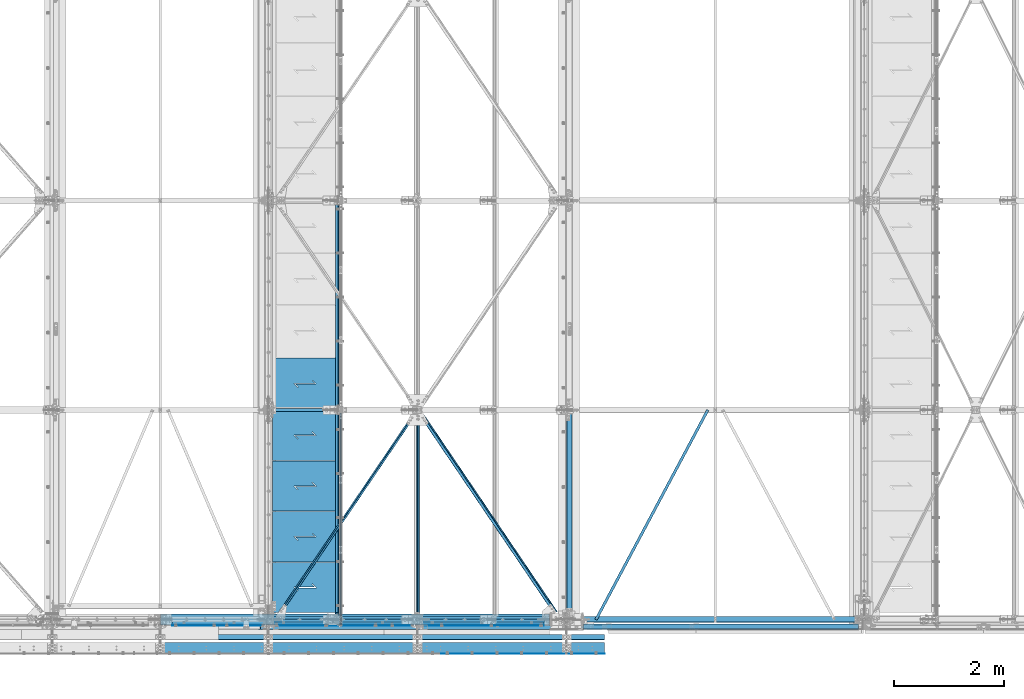
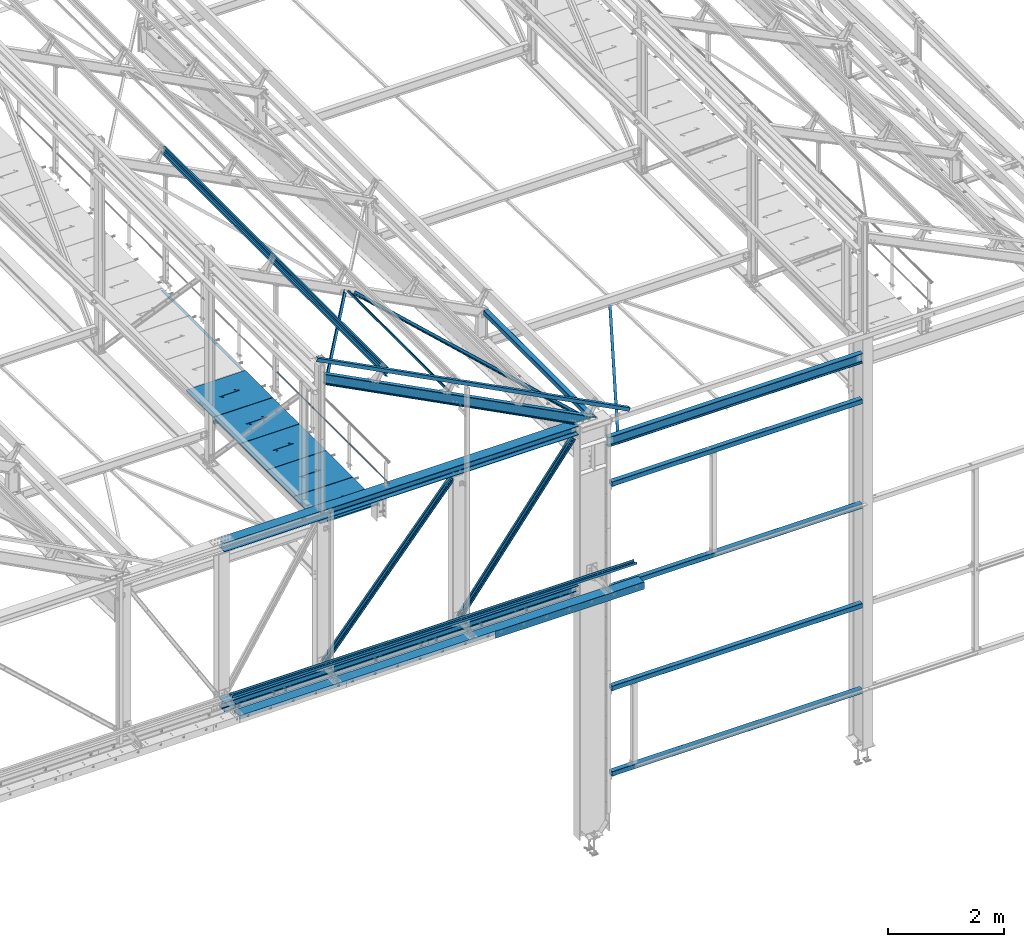
# One storey, part 48 of 496: 26 beams, 6 members, 32 elements without a shape of their own.
"""IFC2X3 building model written with IfcOpenShell, lengths in millimetres."""

from ifc_helpers import new_model, si_unit, frame, origin_with_axes, origin_2d_with_axis, place, context, subcontext, project, spatial, polyline, rectangle, hollow_rectangle, hollow_circle, i_section, l_section, u_section, outline, extrude, boolean, clip, halfspace, material, type_object, element, aggregate, save


model = new_model("IFC2X3")

# Units and contexts
model_context = context("Model", 3, precision=1e-05, world=origin_with_axes())
body_context = subcontext(model_context, "Body", "Model", "MODEL_VIEW")
ifc_project = project(units=[si_unit("LENGTHUNIT", "METRE", prefix="MILLI"), si_unit("AREAUNIT", "SQUARE_METRE"), si_unit("VOLUMEUNIT", "CUBIC_METRE"), si_unit("MASSUNIT", "GRAM", prefix="KILO"), si_unit("TIMEUNIT", "SECOND"), si_unit("PLANEANGLEUNIT", "RADIAN"), si_unit("SOLIDANGLEUNIT", "STERADIAN"), si_unit("THERMODYNAMICTEMPERATUREUNIT", "DEGREE_CELSIUS"), si_unit("LUMINOUSINTENSITYUNIT", "LUMEN")], contexts=[model_context])

# Site, building, storey
site_placement = place(None, origin_with_axes())
site = spatial("IfcSite", under=ifc_project, at=site_placement, CompositionType="ELEMENT")
building_placement = place(site_placement, origin_with_axes())
building = spatial("IfcBuilding", under=site, at=building_placement, Name="Undefined", CompositionType="ELEMENT")
storey_placement = place(building_placement, origin_with_axes())
storey = spatial("IfcBuildingStorey", under=building, at=storey_placement, Name="Undefined", CompositionType="ELEMENT", Elevation=0.0)

# Assembly, beam
assembly_1_placement = place(storey_placement, origin_with_axes())
assembly_1 = element("IfcElementAssembly", 1, at=assembly_1_placement, inside=storey, AssemblyPlace="NOTDEFINED", PredefinedType="NOTDEFINED")
ifc_material_1 = material(Name="Undefined/S235-E24")
beam_type_1 = type_object("IfcBeamType", PredefinedType="NOTDEFINED")
beam_1_placement = place(assembly_1_placement, frame((29413.2405270353, -3.98847032546837, 7825.02116772689), z_axis=(0.882450948164099, -0.47017230311602, 0.0147759760036461), x_axis=(0.470404426089172, 0.882015499167199, -0.0277188590052545)))
beam_1 = element("IfcBeam", 2, at=beam_1_placement, type_object=beam_type_1, material=ifc_material_1, context=body_context, shape_type="SweptSolid", body=[
    extrude(l_section(Depth=50.0, Width=50.0, Thickness=5.0, FilletRadius=7.0, EdgeRadius=3.5, at=origin_2d_with_axis()), frame((4311.66067509402, 8.94535623785865e-13, 6.6380908567593e-14), z_axis=(-1.0, 0.0, 0.0), x_axis=(0.0, -1.0, 0.0)), (0.0, 0.0, 1.0), 4311.66),
])
aggregate(assembly_1, [beam_1])

assembly_2_placement = place(storey_placement, origin_with_axes())
assembly_2 = element("IfcElementAssembly", 3, at=assembly_2_placement, inside=storey, Name="SUPPORT", AssemblyPlace="NOTDEFINED", PredefinedType="NOTDEFINED")
beam_2_placement = place(assembly_2_placement, frame((24711.491600332, 7595.00000000005, 8075.0), z_axis=(-1.0, 0.0, 0.0), x_axis=(0.0, -1.0, 0.0)))
beam_2 = element("IfcBeam", 4, at=beam_2_placement, type_object=beam_type_1, material=ifc_material_1, Name="SUPPORT", context=body_context, shape_type="SweptSolid", body=[
    extrude(l_section(Depth=50.0, Width=50.0, Thickness=5.0, FilletRadius=7.0, EdgeRadius=3.5, at=origin_2d_with_axis()), frame((7469.99982384897, 0.0, 0.0), z_axis=(-1.0, 0.0, 0.0), x_axis=(0.0, -1.0, 0.0)), (0.0, 0.0, 1.0), 7470.0),
])
aggregate(assembly_2, [beam_2])

assembly_3_placement = place(storey_placement, origin_with_axes())
assembly_3 = element("IfcElementAssembly", 5, at=assembly_3_placement, inside=storey, AssemblyPlace="NOTDEFINED", PredefinedType="NOTDEFINED")
beam_type_2 = type_object("IfcBeamType", PredefinedType="NOTDEFINED")
beam_3_placement = place(assembly_3_placement, frame((28762.7486131771, 1.81867566696019, 8583.73904157683), z_axis=(-0.70611707829274, -0.606225541427049, 0.365908820151697), x_axis=(-0.538249840883414, 0.79529277182776, 0.278920267939601)))
beam_3 = element("IfcBeam", 6, at=beam_3_placement, type_object=beam_type_2, material=ifc_material_1, context=body_context, shape_type="Clipping", body=[
    clip(clip(extrude(l_section(Depth=60.0, Width=60.0, Thickness=6.0, FilletRadius=8.0, EdgeRadius=4.0, at=origin_2d_with_axis()), frame((4708.91289425565, 0.0, -3.8340266889476e-12), z_axis=(-1.0, 0.0, 0.0), x_axis=(0.0, -1.0, 0.0)), (0.0, 0.0, 1.0), 4639.71), halfspace(frame((4626.03085826945, 29.999945784366, -30.0000015337173), z_axis=(-1.0, 0.0, 0.0), x_axis=(0.0, 0.0, 1.0)), True)), halfspace(frame((152.084204273029, 29.9999207803739, 29.9999999275933), z_axis=(1.0, 0.0, 0.0), x_axis=(0.0, 0.0, -1.0)), True)),
])
aggregate(assembly_3, [beam_3])

assembly_4_placement = place(storey_placement, origin_with_axes())
assembly_4 = element("IfcElementAssembly", 7, at=assembly_4_placement, inside=storey, AssemblyPlace="NOTDEFINED", PredefinedType="NOTDEFINED")
beam_4_placement = place(assembly_4_placement, frame((26186.6844465445, 3801.81867700377, 9918.65169572219), z_axis=(0.706117063313599, -0.606225551624848, -0.365908832162506), x_axis=(-0.538249844036752, -0.795292764054313, 0.27892028401904)))
beam_4 = element("IfcBeam", 8, at=beam_4_placement, type_object=beam_type_2, material=ifc_material_1, context=body_context, shape_type="Clipping", body=[
    clip(clip(extrude(l_section(Depth=60.0, Width=60.0, Thickness=6.0, FilletRadius=8.0, EdgeRadius=4.0, at=origin_2d_with_axis()), frame((4700.97218490528, -1.30478188945107e-13, 5.21912755780427e-13), z_axis=(-1.0, 0.0, 0.0), x_axis=(0.0, -1.0, 0.0)), (0.0, 0.0, 1.0), 4623.83), halfspace(frame((4626.03039444976, 29.9999208122827, 29.999999976033), z_axis=(-1.0, 0.0, 0.0), x_axis=(0.0, -1.0, 0.0)), True)), halfspace(frame((152.083740436687, 29.999946654003, -29.9999999681386), z_axis=(1.0, 0.0, 0.0), x_axis=(0.0, -1.0, 0.0)), True)),
])
aggregate(assembly_4, [beam_4])

assembly_5_placement = place(storey_placement, origin_with_axes())
assembly_5 = element("IfcElementAssembly", 9, at=assembly_5_placement, inside=storey, Name="SUPPORT", AssemblyPlace="NOTDEFINED", PredefinedType="NOTDEFINED")
beam_type_3 = type_object("IfcBeamType", PredefinedType="NOTDEFINED")
beam_5_placement = place(assembly_5_placement, frame((26605.0000059717, -622.0, 5154.99824538435), z_axis=(0.0, 0.0, 1.0), x_axis=(1.0, 0.0, 0.0)))
beam_5 = element("IfcBeam", 10, at=beam_5_placement, type_object=beam_type_3, material=ifc_material_1, Name="SUPPORT", context=body_context, shape_type="SweptSolid", body=[
    extrude(rectangle(XDim=4.0, YDim=150.0, at=origin_2d_with_axis()), frame((2964.99999402831, 0.0, 0.0), z_axis=(-1.0, 0.0, 0.0), x_axis=(0.0, -1.0, 0.0)), (0.0, 0.0, 1.0), 2965.0),
])
aggregate(assembly_5, [beam_5])

assembly_6_placement = place(storey_placement, origin_with_axes())
assembly_6 = element("IfcElementAssembly", 11, at=assembly_6_placement, inside=storey, Name="SUPPORT", AssemblyPlace="NOTDEFINED", PredefinedType="NOTDEFINED")
beam_type_4 = type_object("IfcBeamType", PredefinedType="NOTDEFINED")
beam_6_placement = place(assembly_6_placement, frame((29570.0, -320.0, 5474.99824538435), z_axis=(0.0, -1.0, 0.0), x_axis=(-1.0, 0.0, 0.0)))
beam_6 = element("IfcBeam", 12, at=beam_6_placement, type_object=beam_type_4, material=ifc_material_1, Name="SUPPORT", context=body_context, shape_type="SweptSolid", body=[
    extrude(u_section(Depth=100.0, FlangeWidth=50.0, WebThickness=4.0, FlangeThickness=4.0, at=origin_2d_with_axis()), frame((8055.00000597169, 0.0, 0.0), z_axis=(-1.0, 0.0, 0.0), x_axis=(0.0, -1.0, 0.0)), (0.0, 0.0, 1.0), 8055.0),
])
aggregate(assembly_6, [beam_6])

assembly_7_placement = place(storey_placement, origin_with_axes())
assembly_7 = element("IfcElementAssembly", 13, at=assembly_7_placement, inside=storey, Name="SUPPORT", AssemblyPlace="NOTDEFINED", PredefinedType="NOTDEFINED")
ifc_material_2 = material(Name="Undefined/S275-E28")
beam_type_5 = type_object("IfcBeamType", Name="UPN200", PredefinedType="NOTDEFINED")
beam_7_placement = place(assembly_7_placement, frame((21514.9999940283, -520.0, 5192.49824538435), z_axis=(0.0, -1.0, 0.0), x_axis=(1.0, 0.0, 0.0)))
beam_7 = element("IfcBeam", 14, at=beam_7_placement, type_object=beam_type_5, material=ifc_material_2, Name="SUPPORT", ObjectType="UPN200", context=body_context, shape_type="SweptSolid", body=[
    extrude(u_section(Depth=200.0, FlangeWidth=75.0, WebThickness=8.5, FlangeThickness=11.5, FilletRadius=11.5, EdgeRadius=6.0, FlangeSlope=0.0798299857122373, at=origin_2d_with_axis()), frame((8055.00000597169, 0.0, 0.0), z_axis=(-1.0, 0.0, 0.0), x_axis=(0.0, -1.0, 0.0)), (0.0, 0.0, 1.0), 8055.0),
])
aggregate(assembly_7, [beam_7])

assembly_8_placement = place(storey_placement, origin_with_axes())
assembly_8 = element("IfcElementAssembly", 15, at=assembly_8_placement, inside=storey, Name="SUPPORT", AssemblyPlace="NOTDEFINED", PredefinedType="NOTDEFINED")
beam_type_6 = type_object("IfcBeamType", PredefinedType="NOTDEFINED")
beam_8_placement = place(assembly_8_placement, frame((21730.0012583757, -105.0, 5040.00085614788), z_axis=(0.0, 0.0, 1.0), x_axis=(1.0, 0.0, 0.0)))
beam_8 = element("IfcBeam", 16, at=beam_8_placement, type_object=beam_type_6, material=ifc_material_1, Name="SUPPORT", context=body_context, shape_type="SweptSolid", body=[
    extrude(rectangle(XDim=10.0, YDim=80.0, at=origin_2d_with_axis()), frame((6734.99874155707, 2.78553019229252e-21, 0.0), z_axis=(-1.0, 0.0, 0.0), x_axis=(0.0, -1.0, 0.0)), (0.0, 0.0, 1.0), 6735.0),
])
aggregate(assembly_8, [beam_8])

assembly_9_placement = place(storey_placement, origin_with_axes())
assembly_9 = element("IfcElementAssembly", 17, at=assembly_9_placement, inside=storey, Name="LISSE", AssemblyPlace="NOTDEFINED", PredefinedType="NOTDEFINED")
beam_type_7 = type_object("IfcBeamType", PredefinedType="NOTDEFINED")
beam_9_placement = place(assembly_9_placement, frame((29185.0000015707, -129.999823796242, 7150.00000003501), z_axis=(0.0, 0.0, -1.0), x_axis=(1.0, 0.0, 0.0)))
beam_9 = element("IfcBeam", 18, at=beam_9_placement, type_object=beam_type_7, material=ifc_material_1, Name="LISSE", context=body_context, shape_type="SweptSolid", body=[
    extrude(hollow_rectangle(XDim=100.0, YDim=100.0, WallThickness=4.0, InnerFilletRadius=4.0, OuterFilletRadius=8.0, at=origin_2d_with_axis()), frame((4989.99999787802, 9.78039819338819e-22, 0.0), z_axis=(-1.0, 0.0, 0.0), x_axis=(0.0, -1.0, 0.0)), (0.0, 0.0, 1.0), 4990.0),
])
aggregate(assembly_9, [beam_9])

assembly_10_placement = place(storey_placement, origin_with_axes())
assembly_10 = element("IfcElementAssembly", 19, at=assembly_10_placement, inside=storey, Name="LISSE", AssemblyPlace="NOTDEFINED", PredefinedType="NOTDEFINED")
beam_10_placement = place(assembly_10_placement, frame((29185.0000022644, -129.999823796467, 4950.00000003405), z_axis=(0.0, 0.0, 1.0), x_axis=(1.0, 0.0, 0.0)))
beam_10 = element("IfcBeam", 20, at=beam_10_placement, type_object=beam_type_7, material=ifc_material_1, Name="LISSE", context=body_context, shape_type="SweptSolid", body=[
    extrude(hollow_rectangle(XDim=100.0, YDim=100.0, WallThickness=4.0, InnerFilletRadius=4.0, OuterFilletRadius=8.0, at=origin_2d_with_axis()), frame((4989.99999787802, 9.78039819338819e-22, 0.0), z_axis=(-1.0, 0.0, 0.0), x_axis=(0.0, -1.0, 0.0)), (0.0, 0.0, 1.0), 4990.0),
])
aggregate(assembly_10, [beam_10])

assembly_11_placement = place(storey_placement, origin_with_axes())
assembly_11 = element("IfcElementAssembly", 21, at=assembly_11_placement, inside=storey, Name="LISSE", AssemblyPlace="NOTDEFINED", PredefinedType="NOTDEFINED")
beam_11_placement = place(assembly_11_placement, frame((29185.0000015707, -129.999823796034, 2850.00000003501), z_axis=(0.0, 0.0, -1.0), x_axis=(1.0, 0.0, 0.0)))
beam_11 = element("IfcBeam", 22, at=beam_11_placement, type_object=beam_type_7, material=ifc_material_1, Name="LISSE", context=body_context, shape_type="SweptSolid", body=[
    extrude(hollow_rectangle(XDim=100.0, YDim=100.0, WallThickness=4.0, InnerFilletRadius=4.0, OuterFilletRadius=8.0, at=origin_2d_with_axis()), frame((4989.99999787802, 9.78039819338819e-22, 0.0), z_axis=(-1.0, 0.0, 0.0), x_axis=(0.0, -1.0, 0.0)), (0.0, 0.0, 1.0), 4990.0),
])
aggregate(assembly_11, [beam_11])

assembly_12_placement = place(storey_placement, origin_with_axes())
assembly_12 = element("IfcElementAssembly", 23, at=assembly_12_placement, inside=storey, Name="LISSE", AssemblyPlace="NOTDEFINED", PredefinedType="NOTDEFINED")
beam_12_placement = place(assembly_12_placement, frame((29185.0000022644, -129.999823796391, 1050.00000003405), z_axis=(0.0, 0.0, 1.0), x_axis=(1.0, 0.0, 0.0)))
beam_12 = element("IfcBeam", 24, at=beam_12_placement, type_object=beam_type_7, material=ifc_material_1, Name="LISSE", context=body_context, shape_type="SweptSolid", body=[
    extrude(hollow_rectangle(XDim=100.0, YDim=100.0, WallThickness=4.0, InnerFilletRadius=4.0, OuterFilletRadius=8.0, at=origin_2d_with_axis()), frame((4989.99999787802, 9.78039819338819e-22, 0.0), z_axis=(-1.0, 0.0, 0.0), x_axis=(0.0, -1.0, 0.0)), (0.0, 0.0, 1.0), 4990.0),
])
aggregate(assembly_12, [beam_12])

assembly_13_placement = place(storey_placement, origin_with_axes())
assembly_13 = element("IfcElementAssembly", 25, at=assembly_13_placement, inside=storey, Name="LISSE", AssemblyPlace="NOTDEFINED", PredefinedType="NOTDEFINED")
beam_13_placement = place(assembly_13_placement, frame((28929.9999999877, 120.0, 8500.0), z_axis=(0.0, 0.0, 1.0), x_axis=(0.0, 1.0, 0.0)))
beam_13 = element("IfcBeam", 26, at=beam_13_placement, type_object=beam_type_7, material=ifc_material_1, Name="LISSE", context=body_context, shape_type="SweptSolid", body=[
    extrude(hollow_rectangle(XDim=100.0, YDim=100.0, WallThickness=4.0, InnerFilletRadius=4.0, OuterFilletRadius=8.0, at=origin_2d_with_axis()), frame((3610.0, 0.0, 0.0), z_axis=(-1.0, 0.0, 0.0), x_axis=(0.0, -1.0, 0.0)), (0.0, 0.0, 1.0), 3610.0),
])
aggregate(assembly_13, [beam_13])

assembly_14_placement = place(storey_placement, origin_with_axes())
assembly_14 = element("IfcElementAssembly", 27, at=assembly_14_placement, inside=storey, AssemblyPlace="NOTDEFINED", PredefinedType="NOTDEFINED")
beam_type_8 = type_object("IfcBeamType", PredefinedType="NOTDEFINED")
beam_14_placement = place(assembly_14_placement, frame((24726.4916105611, 1035.00017615107, 8115.0), z_axis=(0.0, 0.0, 1.0), x_axis=(-1.0, 0.0, 0.0)))
beam_14 = element("IfcBeam", 28, at=beam_14_placement, type_object=beam_type_8, material=ifc_material_1, context=body_context, shape_type="CSG", body=[
    boolean("DIFFERENCE", extrude(outline(polyline([(0.0, 0.0), (1179.99169921875, 0.0), (1179.99169921875, 910.0), (-9.39995516091585e-07, 910.0), (0.0, 0.0)])), frame((0.0, 0.0, -15.0), z_axis=(0.0, 0.0, 1.0), x_axis=(1.0, 0.0, 0.0)), (0.0, 0.0, 1.0), 30.0), extrude(outline(polyline([(0.0, 0.0), (9.99999999997453, 6.91215973347425e-11), (10.0000000004329, 75.8578643791443), (282.842712400121, -196.984848017997), (282.842712400743, -96.9848480190813), (272.842712400776, -96.9848480191613), (272.842712400299, -172.842712398218), (0.0, 100.0), (0.0, 0.0)])), frame((724.285170968404, 520.710678119967, -17.5), z_axis=(0.0, 0.0, 1.0), x_axis=(-0.707106781186457, -0.707106781186639, 0.0)), (0.0, 0.0, 1.0), 35.0)),
])
aggregate(assembly_14, [beam_14])

assembly_15_placement = place(storey_placement, origin_with_axes())
assembly_15 = element("IfcElementAssembly", 29, at=assembly_15_placement, inside=storey, AssemblyPlace="NOTDEFINED", PredefinedType="NOTDEFINED")
beam_15_placement = place(assembly_15_placement, frame((24726.4916105611, 1955.00017138181, 8115.0), z_axis=(0.0, 0.0, 1.0), x_axis=(-1.0, 0.0, 0.0)))
beam_15 = element("IfcBeam", 30, at=beam_15_placement, type_object=beam_type_8, material=ifc_material_1, context=body_context, shape_type="CSG", body=[
    boolean("DIFFERENCE", extrude(outline(polyline([(0.0, 0.0), (1179.99169921875, 0.0), (1179.99169921875, 910.0), (-9.39995516091585e-07, 910.0), (0.0, 0.0)])), frame((0.0, 0.0, -15.0), z_axis=(0.0, 0.0, 1.0), x_axis=(1.0, 0.0, 0.0)), (0.0, 0.0, 1.0), 30.0), extrude(outline(polyline([(0.0, 0.0), (9.99999999997453, 6.91215973347425e-11), (10.0000000004329, 75.8578643791443), (282.842712400121, -196.984848017997), (282.842712400743, -96.9848480190813), (272.842712400776, -96.9848480191613), (272.842712400299, -172.842712398218), (0.0, 100.0), (0.0, 0.0)])), frame((724.285170968404, 520.710678119967, -17.5), z_axis=(0.0, 0.0, 1.0), x_axis=(-0.707106781186457, -0.707106781186639, 0.0)), (0.0, 0.0, 1.0), 35.0)),
])
aggregate(assembly_15, [beam_15])

assembly_16_placement = place(storey_placement, origin_with_axes())
assembly_16 = element("IfcElementAssembly", 31, at=assembly_16_placement, inside=storey, AssemblyPlace="NOTDEFINED", PredefinedType="NOTDEFINED")
beam_16_placement = place(assembly_16_placement, frame((24726.4916105611, 2875.00016661255, 8115.0), z_axis=(0.0, 0.0, 1.0), x_axis=(-1.0, 0.0, 0.0)))
beam_16 = element("IfcBeam", 32, at=beam_16_placement, type_object=beam_type_8, material=ifc_material_1, context=body_context, shape_type="CSG", body=[
    boolean("DIFFERENCE", extrude(outline(polyline([(0.0, 0.0), (1179.99169921875, 0.0), (1179.99169921875, 910.0), (-9.39995516091585e-07, 910.0), (0.0, 0.0)])), frame((0.0, 0.0, -15.0), z_axis=(0.0, 0.0, 1.0), x_axis=(1.0, 0.0, 0.0)), (0.0, 0.0, 1.0), 30.0), extrude(outline(polyline([(0.0, 0.0), (9.99999999997453, 6.91215973347425e-11), (10.0000000004329, 75.8578643791443), (282.842712400121, -196.984848017997), (282.842712400743, -96.9848480190813), (272.842712400776, -96.9848480191613), (272.842712400299, -172.842712398218), (0.0, 100.0), (0.0, 0.0)])), frame((724.285170968404, 520.710678119967, -17.5), z_axis=(0.0, 0.0, 1.0), x_axis=(-0.707106781186457, -0.707106781186639, 0.0)), (0.0, 0.0, 1.0), 35.0)),
])
aggregate(assembly_16, [beam_16])

assembly_17_placement = place(storey_placement, origin_with_axes())
assembly_17 = element("IfcElementAssembly", 33, at=assembly_17_placement, inside=storey, AssemblyPlace="NOTDEFINED", PredefinedType="NOTDEFINED")
beam_17_placement = place(assembly_17_placement, frame((24726.4916105611, 3795.00016184328, 8115.0), z_axis=(0.0, 0.0, 1.0), x_axis=(-1.0, 0.0, 0.0)))
beam_17 = element("IfcBeam", 34, at=beam_17_placement, type_object=beam_type_8, material=ifc_material_1, context=body_context, shape_type="CSG", body=[
    boolean("DIFFERENCE", extrude(outline(polyline([(0.0, 0.0), (1179.99169921875, 0.0), (1179.99169921875, 910.0), (-9.39995516091585e-07, 910.0), (0.0, 0.0)])), frame((0.0, 0.0, -15.0), z_axis=(0.0, 0.0, 1.0), x_axis=(1.0, 0.0, 0.0)), (0.0, 0.0, 1.0), 30.0), extrude(outline(polyline([(0.0, 0.0), (9.99999999997453, 6.91215973347425e-11), (10.0000000004329, 75.8578643791443), (282.842712400121, -196.984848017997), (282.842712400743, -96.9848480190813), (272.842712400776, -96.9848480191613), (272.842712400299, -172.842712398218), (0.0, 100.0), (0.0, 0.0)])), frame((724.285170968404, 520.710678119967, -17.5), z_axis=(0.0, 0.0, 1.0), x_axis=(-0.707106781186457, -0.707106781186639, 0.0)), (0.0, 0.0, 1.0), 35.0)),
])
aggregate(assembly_17, [beam_17])

assembly_18_placement = place(storey_placement, origin_with_axes())
assembly_18 = element("IfcElementAssembly", 35, at=assembly_18_placement, inside=storey, AssemblyPlace="NOTDEFINED", PredefinedType="NOTDEFINED")
beam_type_9 = type_object("IfcBeamType", PredefinedType="NOTDEFINED")
beam_18_placement = place(assembly_18_placement, frame((24726.4915934611, 4745.00015707402, 8115.0), z_axis=(0.0, 0.0, 1.0), x_axis=(-1.0, 0.0, 0.0)))
beam_18 = element("IfcBeam", 36, at=beam_18_placement, type_object=beam_type_9, material=ifc_material_1, context=body_context, shape_type="CSG", body=[
    boolean("DIFFERENCE", extrude(outline(polyline([(0.0, 0.0), (1179.99169921875, 0.0), (1179.99169921875, 940.0), (-9.39995516091585e-07, 940.0), (0.0, 0.0)])), frame((0.0, 0.0, -15.0), z_axis=(0.0, 0.0, 1.0), x_axis=(1.0, 0.0, 0.0)), (0.0, 0.0, 1.0), 30.0), extrude(outline(polyline([(0.0, 0.0), (9.99999999997453, 6.91215973347425e-11), (10.0000000004329, 75.8578643791443), (282.842712400121, -196.984848017997), (282.842712400743, -96.9848480190813), (272.842712400776, -96.9848480191613), (272.842712400299, -172.842712398218), (0.0, 100.0), (0.0, 0.0)])), frame((724.286946489367, 535.710676888644, -17.5), z_axis=(0.0, 0.0, 1.0), x_axis=(-0.707106781186457, -0.707106781186639, 0.0)), (0.0, 0.0, 1.0), 35.0)),
])
aggregate(assembly_18, [beam_18])

assembly_19_placement = place(storey_placement, origin_with_axes())
assembly_19 = element("IfcElementAssembly", 37, at=assembly_19_placement, inside=storey, Name="SUPPORT", AssemblyPlace="NOTDEFINED", PredefinedType="NOTDEFINED")
beam_type_10 = type_object("IfcBeamType", PredefinedType="NOTDEFINED")
beam_19_placement = place(assembly_19_placement, frame((21730.0012582974, -64.998477916576, 5045.00085614788), z_axis=(0.0, 1.0, 0.0), x_axis=(1.0, 0.0, 0.0)))
beam_19 = element("IfcBeam", 38, at=beam_19_placement, type_object=beam_type_10, material=ifc_material_1, Name="SUPPORT", context=body_context, shape_type="SweptSolid", body=[
    extrude(l_section(Depth=70.0, Width=70.0, Thickness=7.0, FilletRadius=9.0, EdgeRadius=4.5, at=origin_2d_with_axis()), frame((6734.99874155707, 2.78553019229252e-21, 0.0), z_axis=(-1.0, 0.0, 0.0), x_axis=(0.0, -1.0, 0.0)), (0.0, 0.0, 1.0), 6735.0),
])
aggregate(assembly_19, [beam_19])

assembly_20_placement = place(storey_placement, origin_with_axes())
assembly_20 = element("IfcElementAssembly", 39, at=assembly_20_placement, inside=storey, Name="MAIN COURANTE", AssemblyPlace="NOTDEFINED", PredefinedType="NOTDEFINED")
beam_type_11 = type_object("IfcBeamType", PredefinedType="NOTDEFINED")
beam_20_placement = place(assembly_20_placement, frame((24783.9916006735, 3745.00000183788, 8673.80000478164), z_axis=(0.0, 0.0, 1.0), x_axis=(0.0, -1.0, 0.0)))
beam_20 = element("IfcBeam", 40, at=beam_20_placement, type_object=beam_type_11, material=ifc_material_1, Name="LISSE", context=body_context, shape_type="SweptSolid", body=[
    extrude(hollow_circle(Radius=13.44999981, WallThickness=2.0, at=origin_2d_with_axis()), frame((3844.99656169932, 3.84499533570735e-24, 0.0), z_axis=(-1.0, 0.0, 0.0), x_axis=(0.0, -1.0, 0.0)), (0.0, 0.0, 1.0), 3845.0),
])
aggregate(assembly_20, [beam_20])

assembly_21_placement = place(storey_placement, origin_with_axes())
assembly_21 = element("IfcElementAssembly", 41, at=assembly_21_placement, inside=storey, AssemblyPlace="NOTDEFINED", PredefinedType="NOTDEFINED")
beam_type_12 = type_object("IfcBeamType", PredefinedType="NOTDEFINED")
beam_21_placement = place(assembly_21_placement, frame((26184.2061440776, 3720.00174668243, 9908.67304621165), z_axis=(-0.887870604061621, -1.29999898490562e-08, 0.460093241031915), x_axis=(0.0, -1.0, 0.0)))
beam_21 = element("IfcBeam", 42, at=beam_21_placement, type_object=beam_type_12, material=ifc_material_1, context=body_context, shape_type="SweptSolid", body=[
    extrude(hollow_rectangle(XDim=40.0, YDim=40.0, WallThickness=4.0, InnerFilletRadius=4.0, OuterFilletRadius=8.0, at=origin_2d_with_axis()), frame((3700.00159576542, -3.63797880709171e-12, -3.63797880709171e-12), z_axis=(-1.0, 0.0, 0.0), x_axis=(0.0, -1.0, 0.0)), (0.0, 0.0, 1.0), 3700.0),
])
aggregate(assembly_21, [beam_21])

assembly_22_placement = place(storey_placement, origin_with_axes())
assembly_22 = element("IfcElementAssembly", 43, at=assembly_22_placement, inside=storey, Name="TRAVERSE BASSE", AssemblyPlace="NOTDEFINED", PredefinedType="NOTDEFINED")
beam_type_13 = type_object("IfcBeamType", Name="HEA200", PredefinedType="NOTDEFINED")
beam_22_placement = place(assembly_22_placement, frame((21514.9998483183, 0.0, 5095.00174292274), z_axis=(0.0, 0.0, 1.0), x_axis=(1.0, 0.0, 0.0)))
beam_22 = element("IfcBeam", 44, at=beam_22_placement, type_object=beam_type_13, material=ifc_material_2, Name="TRAVERSE BASSE", ObjectType="HEA200", context=body_context, shape_type="SweptSolid", body=[
    extrude(i_section(OverallWidth=200.0, OverallDepth=190.0, WebThickness=6.5, FlangeThickness=10.0, FilletRadius=18.0, at=origin_2d_with_axis()), frame((7055.00017515165, 0.0, 0.0), z_axis=(-1.0, 0.0, 0.0), x_axis=(0.0, -1.0, 0.0)), (0.0, 0.0, 1.0), 7055.0),
])
aggregate(assembly_22, [beam_22])

assembly_23_placement = place(storey_placement, origin_with_axes())
assembly_23 = element("IfcElementAssembly", 45, at=assembly_23_placement, inside=storey, Name="TRAVERSE HAUTE", AssemblyPlace="NOTDEFINED", PredefinedType="NOTDEFINED")
beam_23_placement = place(assembly_23_placement, frame((28569.99997653, 0.0, 8454.99444626714), z_axis=(0.0, 0.0, -1.0), x_axis=(-1.0, 0.0, 0.0)))
beam_23 = element("IfcBeam", 46, at=beam_23_placement, type_object=beam_type_13, material=ifc_material_2, Name="TRAVERSE HAUTE", ObjectType="HEA200", context=body_context, shape_type="SweptSolid", body=[
    extrude(i_section(OverallWidth=200.0, OverallDepth=190.0, WebThickness=6.5, FlangeThickness=10.0, FilletRadius=18.0, at=origin_2d_with_axis()), frame((7055.00017515165, 0.0, 0.0), z_axis=(-1.0, 0.0, 0.0), x_axis=(0.0, -1.0, 0.0)), (0.0, 0.0, 1.0), 7055.0),
])
aggregate(assembly_23, [beam_23])

assembly_24_placement = place(storey_placement, origin_with_axes())
assembly_24 = element("IfcElementAssembly", 47, at=assembly_24_placement, inside=storey, Name="SHED", AssemblyPlace="NOTDEFINED", PredefinedType="NOTDEFINED")
beam_type_14 = type_object("IfcBeamType", PredefinedType="NOTDEFINED")
beam_24_placement = place(assembly_24_placement, frame((24738.4311443321, -154.999920381521, 11040.8102083729), z_axis=(0.460093364927087, 0.0, 0.887870539859315), x_axis=(0.0, 1.0, 0.0)))
beam_24 = element("IfcBeam", 48, at=beam_24_placement, type_object=beam_type_14, material=ifc_material_1, Name="SHED", context=body_context, shape_type="SweptSolid", body=[
    extrude(outline(polyline([(-27.9999999860338, 36.0000000101354), (-27.999999986052, 70.0000000101354), (28.0000000138389, 70.0000000101209), (28.0000000138425, 58.0000000101209), (26.5000000138534, 58.0000000101209), (26.5000000138352, 68.5000000101172), (-26.4999999860593, 68.5000000101354), (-26.4999999860338, 36.7000007730749), (-1.49999998607018, 15.6999998194005), (-1.49999998605563, -15.6999997991297), (-26.4999999859974, -36.7000007527895), (-26.4999999859829, -68.49999998985), (26.5000000139153, -68.4999999898646), (26.500000013908, -57.9999999898646), (28.0000000139116, -57.9999999898646), (28.0000000139153, -69.9999999898646), (-27.9999999859756, -69.99999998985), (-27.9999999859901, -35.99999998985), (-2.99999998605927, -14.9999999898646), (-2.9999999860629, 15.0000000101354), (-27.9999999860338, 36.0000000101354)])), frame((7750.00000000006, -3.63797880548905e-12, 0.0), z_axis=(-1.0, 0.0, 0.0), x_axis=(0.0, -1.0, 0.0)), (0.0, 0.0, 1.0), 7750.0),
])
aggregate(assembly_24, [beam_24])

# Assembly, member
assembly_25_placement = place(storey_placement, origin_with_axes())
assembly_25 = element("IfcElementAssembly", 49, at=assembly_25_placement, inside=storey, AssemblyPlace="NOTDEFINED", PredefinedType="NOTDEFINED")
member_type_1 = type_object("IfcMemberType", PredefinedType="NOTDEFINED")
member_1_placement = place(assembly_25_placement, frame((23309.4127399744, -145.0, 11828.6296316058), z_axis=(-0.460093241820242, 0.0, -0.887870603653112), x_axis=(0.887870604061616, 0.0, -0.460093241031926)))
member_1 = element("IfcMember", 50, at=member_1_placement, type_object=member_type_1, material=ifc_material_1, context=body_context, shape_type="SweptSolid", body=[
    extrude(l_section(Depth=70.0, Width=70.0, Thickness=7.0, FilletRadius=9.0, EdgeRadius=4.5, at=origin_2d_with_axis()), frame((7015.00016857142, 0.0, -3.89410735244867e-13), z_axis=(-1.0, 0.0, 0.0), x_axis=(0.0, -1.0, 0.0)), (0.0, 0.0, 1.0), 7015.0),
])
aggregate(assembly_25, [member_1])

assembly_26_placement = place(storey_placement, origin_with_axes())
assembly_26 = element("IfcElementAssembly", 51, at=assembly_26_placement, inside=storey, AssemblyPlace="NOTDEFINED", PredefinedType="NOTDEFINED")
member_type_2 = type_object("IfcMemberType", Name="UPN80", PredefinedType="NOTDEFINED")
member_2_placement = place(assembly_26_placement, frame((23470.0000048533, 27.500000001548, 5190.00068964305), z_axis=(0.760694427649506, 0.0, -0.649110150700935), x_axis=(0.649110147977419, 0.0, 0.760694429973516)))
member_2 = element("IfcMember", 52, at=member_2_placement, type_object=member_type_2, material=ifc_material_2, ObjectType="UPN80", context=body_context, shape_type="Clipping", body=[
    clip(clip(extrude(u_section(Depth=80.0, FlangeWidth=45.0, WebThickness=6.0, FlangeThickness=8.0, FilletRadius=8.0, EdgeRadius=4.0, FlangeSlope=0.0798299857122373, at=origin_2d_with_axis()), frame((4127.0370906706, 3.5527136788005e-15, 4.58193160154452e-13), z_axis=(-1.0, 0.0, 0.0), x_axis=(0.0, -1.0, 0.0)), (0.0, 0.0, 1.0), 4086.83), halfspace(frame((4047.24313549228, 27.500000001548, -39.999999399286), z_axis=(-1.0, 0.0, 0.0), x_axis=(0.0, 1.0, 0.0)), True)), halfspace(frame((119.999999997919, 27.49999999375, -39.9999989691296), z_axis=(-1.0, 0.0, 0.0), x_axis=(0.0, 1.0, 0.0)), False)),
])
aggregate(assembly_26, [member_2])

assembly_27_placement = place(storey_placement, origin_with_axes())
assembly_27 = element("IfcElementAssembly", 53, at=assembly_27_placement, inside=storey, AssemblyPlace="NOTDEFINED", PredefinedType="NOTDEFINED")
member_3_placement = place(assembly_27_placement, frame((26174.9998359929, -27.5000000008872, 8359.9993116999), z_axis=(0.760694427649506, 0.0, -0.649110150700935), x_axis=(-0.649110150700935, 0.0, -0.760694427649506)))
member_3 = element("IfcMember", 54, at=member_3_placement, type_object=member_type_2, material=ifc_material_2, ObjectType="UPN80", context=body_context, shape_type="Clipping", body=[
    clip(clip(extrude(u_section(Depth=80.0, FlangeWidth=45.0, WebThickness=6.0, FlangeThickness=8.0, FilletRadius=8.0, EdgeRadius=4.0, FlangeSlope=0.0798299857122373, at=origin_2d_with_axis()), frame((4127.0370906706, 3.5527136788005e-15, 4.58193160154452e-13), z_axis=(-1.0, 0.0, 0.0), x_axis=(0.0, -1.0, 0.0)), (0.0, 0.0, 1.0), 4086.83), halfspace(frame((4047.24313549228, 27.500000001548, -39.999999399286), z_axis=(1.0, 0.0, 0.0), x_axis=(0.0, -1.0, 0.0)), False)), halfspace(frame((119.999999997919, 27.49999999375, -39.9999989691296), z_axis=(1.0, 0.0, 0.0), x_axis=(0.0, -1.0, 0.0)), True)),
])
aggregate(assembly_27, [member_3])

assembly_28_placement = place(storey_placement, origin_with_axes())
assembly_28 = element("IfcElementAssembly", 55, at=assembly_28_placement, inside=storey, AssemblyPlace="NOTDEFINED", PredefinedType="NOTDEFINED")
member_4_placement = place(assembly_28_placement, frame((26175.0000048474, 27.5000000069931, 5190.00624337595), z_axis=(0.79667022183209, 0.0, -0.604414226872604), x_axis=(0.604414210939447, 0.0, 0.796670233920187)))
member_4 = element("IfcMember", 56, at=member_4_placement, type_object=member_type_2, material=ifc_material_2, ObjectType="UPN80", context=body_context, shape_type="Clipping", body=[
    clip(clip(extrude(u_section(Depth=80.0, FlangeWidth=45.0, WebThickness=6.0, FlangeThickness=8.0, FilletRadius=8.0, EdgeRadius=4.0, FlangeSlope=0.0798299857122373, at=origin_2d_with_axis()), frame((3936.86625748963, 0.0, 0.0), z_axis=(-1.0, 0.0, 0.0), x_axis=(0.0, -1.0, 0.0)), (0.0, 0.0, 1.0), 3894.68), halfspace(frame((3859.05281738359, 27.5000000069931, -40.0000022367931), z_axis=(-1.0, 0.0, 0.0), x_axis=(0.0, 1.0, 0.0)), True)), halfspace(frame((119.999999997919, 27.49999999375, -39.9999989691296), z_axis=(-1.0, 0.0, 0.0), x_axis=(0.0, 1.0, 0.0)), False)),
])
aggregate(assembly_28, [member_4])

assembly_29_placement = place(storey_placement, origin_with_axes())
assembly_29 = element("IfcElementAssembly", 57, at=assembly_29_placement, inside=storey, AssemblyPlace="NOTDEFINED", PredefinedType="NOTDEFINED")
member_5_placement = place(assembly_29_placement, frame((28579.9960922618, -27.5000000018274, 8359.99916813926), z_axis=(0.79667022183209, 0.0, -0.604414226872604), x_axis=(-0.604414226872603, 0.0, -0.796670221832091)))
member_5 = element("IfcMember", 58, at=member_5_placement, type_object=member_type_2, material=ifc_material_2, ObjectType="UPN80", context=body_context, shape_type="Clipping", body=[
    clip(clip(extrude(u_section(Depth=80.0, FlangeWidth=45.0, WebThickness=6.0, FlangeThickness=8.0, FilletRadius=8.0, EdgeRadius=4.0, FlangeSlope=0.0798299857122373, at=origin_2d_with_axis()), frame((3936.86625748963, 0.0, 0.0), z_axis=(-1.0, 0.0, 0.0), x_axis=(0.0, -1.0, 0.0)), (0.0, 0.0, 1.0), 3894.68), halfspace(frame((3859.05281738359, 27.5000000069931, -40.0000022367931), z_axis=(1.0, 0.0, 0.0), x_axis=(0.0, -1.0, 0.0)), False)), halfspace(frame((119.999999997919, 27.49999999375, -39.9999989691296), z_axis=(1.0, 0.0, 0.0), x_axis=(0.0, -1.0, 0.0)), True)),
])
aggregate(assembly_29, [member_5])

# Assembly, beam
assembly_30_placement = place(storey_placement, origin_with_axes())
assembly_30 = element("IfcElementAssembly", 59, at=assembly_30_placement, inside=storey, AssemblyPlace="NOTDEFINED", PredefinedType="NOTDEFINED")
beam_type_15 = type_object("IfcBeamType", PredefinedType="NOTDEFINED")
beam_25_placement = place(assembly_30_placement, frame((23547.9918295866, 3800.0, 8015.0), z_axis=(0.0, -1.0, 0.0), x_axis=(1.0, 0.0, 0.0)))
beam_25 = element("IfcBeam", 60, at=beam_25_placement, type_object=beam_type_15, material=ifc_material_1, context=body_context, shape_type="SweptSolid", body=[
    extrude(hollow_rectangle(XDim=60.0, YDim=60.0, WallThickness=3.0, InnerFilletRadius=3.0, OuterFilletRadius=6.0, at=origin_2d_with_axis()), frame((1181.99977105896, 0.0, 0.0), z_axis=(-1.0, 0.0, 0.0), x_axis=(0.0, -1.0, 0.0)), (0.0, 0.0, 1.0), 1182.0),
])
aggregate(assembly_30, [beam_25])

# Assembly, member
assembly_31_placement = place(storey_placement, origin_with_axes())
assembly_31 = element("IfcElementAssembly", 61, at=assembly_31_placement, inside=storey, Name="TRAVERSE SHED", AssemblyPlace="NOTDEFINED", PredefinedType="NOTDEFINED")
member_type_3 = type_object("IfcMemberType", Name="IPE200", PredefinedType="NOTDEFINED")
member_6_placement = place(assembly_31_placement, frame((23493.9906758887, -3.18409305520222e-09, 11280.2129395988), z_axis=(0.460093364927087, 0.0, 0.887870539859315), x_axis=(0.887870604061616, 0.0, -0.460093241031926)))
member_6 = element("IfcMember", 62, at=member_6_placement, type_object=member_type_3, material=ifc_material_2, Name="TRAVERSE SHED", ObjectType="IPE200", context=body_context, shape_type="Clipping", body=[
    clip(clip(extrude(i_section(OverallWidth=100.0, OverallDepth=200.0, WebThickness=5.599999905, FlangeThickness=8.5, FilletRadius=12.0, at=origin_2d_with_axis()), frame((6159.55202464549, 4.13590306276514e-25, 0.0), z_axis=(-1.0, 0.0, 0.0), x_axis=(0.0, -1.0, 0.0)), (0.0, 0.0, 1.0), 6347.66), halfspace(frame((5354.83248803546, 3.18409305520223e-09, -288.88297891846), z_axis=(-0.460093242228747, -7.1029704621934e-09, 0.887870603441425), x_axis=(0.0, -1.0, 0.0)), True)), halfspace(frame((5.77115893586233, 3.18409305520223e-09, 102.990606066072), z_axis=(-0.887870604061619, 0.0, -0.46009324103192), x_axis=(0.0, -1.0, 0.0)), False)),
])
aggregate(assembly_31, [member_6])

# Assembly, beam
assembly_32_placement = place(storey_placement, origin_with_axes())
assembly_32 = element("IfcElementAssembly", 63, at=assembly_32_placement, inside=storey, AssemblyPlace="NOTDEFINED", PredefinedType="NOTDEFINED")
beam_type_16 = type_object("IfcBeamType", Name="IPE200", PredefinedType="NOTDEFINED")
beam_26_placement = place(assembly_32_placement, frame((29190.0, 2.34376784646884e-09, 7949.95250495457), z_axis=(0.0, 0.031410887010906, 0.999506556345274), x_axis=(1.0, 0.0, 0.0)))
beam_26 = element("IfcBeam", 64, at=beam_26_placement, type_object=beam_type_16, material=ifc_material_2, ObjectType="IPE200", context=body_context, shape_type="SweptSolid", body=[
    extrude(i_section(OverallWidth=100.0, OverallDepth=200.0, WebThickness=5.599999905, FlangeThickness=8.5, FilletRadius=12.0, at=origin_2d_with_axis()), frame((5074.99785576867, 0.0, 0.0), z_axis=(-1.0, 0.0, 0.0), x_axis=(0.0, -1.0, 0.0)), (0.0, 0.0, 1.0), 5075.0),
])
aggregate(assembly_32, [beam_26])

save(model, "model.ifc")
